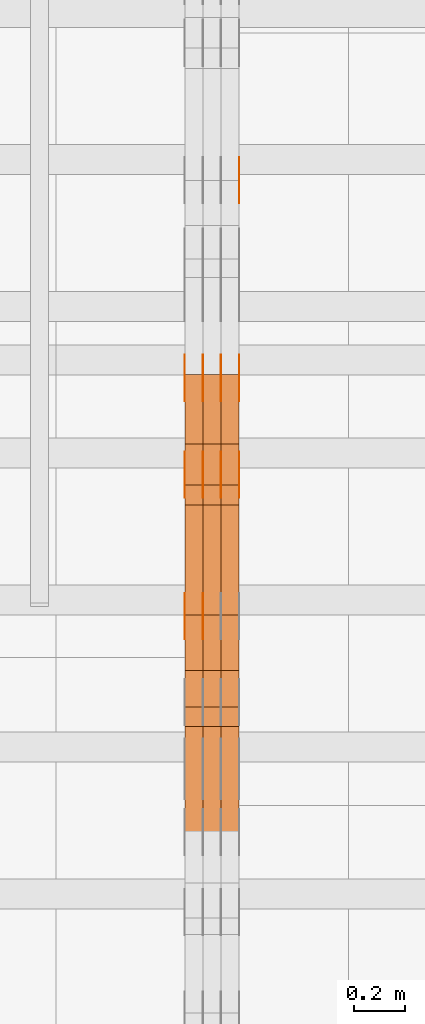
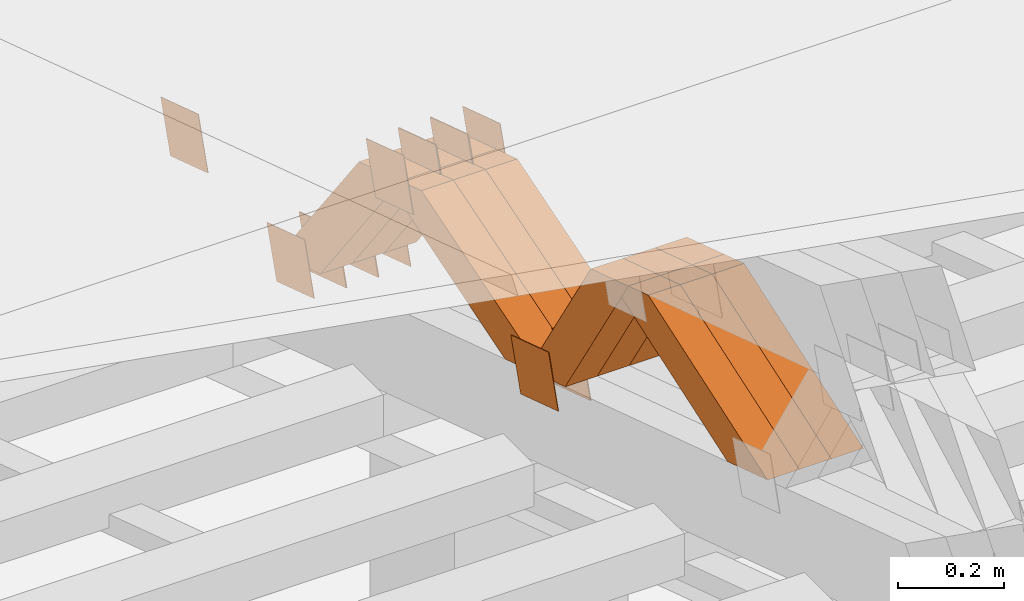
# One storey, part 179 of 385: 28 proxies.
"""IFC2X3 building model written with IfcOpenShell, lengths in millimetres."""

from ifc_helpers import new_model, entity, si_unit, converted_unit, derived_unit, direction, frame, origin, place, context, subcontext, project, spatial, polyline, outline, extrude, source, transform, mapped, material, type_object, type_shapes, element, save


model = new_model("IFC2X3")

# Units and contexts
model_context = context("Model", 3, precision=0.01, world=origin(), true_north=direction((6.12303176911189e-17, 1.0)))
body_context = subcontext(model_context, "Body", "Model", "MODEL_VIEW")
ifc_project = project(units=[si_unit("LENGTHUNIT", "METRE", prefix="MILLI"), si_unit("AREAUNIT", "SQUARE_METRE"), si_unit("VOLUMEUNIT", "CUBIC_METRE"), converted_unit("PLANEANGLEUNIT", "DEGREE", entity("IfcRatioMeasure", 0.0174532925199433), si_unit("PLANEANGLEUNIT", "RADIAN"), dimensions=[0, 0, 0, 0, 0, 0, 0]), si_unit("MASSUNIT", "GRAM", prefix="KILO"), derived_unit("MASSDENSITYUNIT", [(si_unit("MASSUNIT", "GRAM", prefix="KILO"), 1), (si_unit("LENGTHUNIT", "METRE"), -3)]), si_unit("TIMEUNIT", "SECOND"), si_unit("FREQUENCYUNIT", "HERTZ"), si_unit("THERMODYNAMICTEMPERATUREUNIT", "DEGREE_CELSIUS"), derived_unit("THERMALTRANSMITTANCEUNIT", [(si_unit("MASSUNIT", "GRAM", prefix="KILO"), 1), (si_unit("THERMODYNAMICTEMPERATUREUNIT", "KELVIN"), -1), (si_unit("TIMEUNIT", "SECOND"), -3)]), derived_unit("VOLUMETRICFLOWRATEUNIT", [(si_unit("LENGTHUNIT", "METRE"), 3), (si_unit("TIMEUNIT", "SECOND"), -1)]), si_unit("ELECTRICCURRENTUNIT", "AMPERE"), si_unit("ELECTRICVOLTAGEUNIT", "VOLT"), si_unit("POWERUNIT", "WATT"), si_unit("FORCEUNIT", "NEWTON", prefix="KILO"), si_unit("ILLUMINANCEUNIT", "LUX"), si_unit("LUMINOUSFLUXUNIT", "LUMEN"), si_unit("LUMINOUSINTENSITYUNIT", "CANDELA"), derived_unit("USERDEFINED", [(si_unit("MASSUNIT", "GRAM", prefix="KILO"), -1), (si_unit("LENGTHUNIT", "METRE"), -2), (si_unit("TIMEUNIT", "SECOND"), 3), (si_unit("LUMINOUSFLUXUNIT", "LUMEN"), 1)]), derived_unit("LINEARVELOCITYUNIT", [(si_unit("LENGTHUNIT", "METRE"), 1), (si_unit("TIMEUNIT", "SECOND"), -1)]), si_unit("PRESSUREUNIT", "PASCAL"), derived_unit("USERDEFINED", [(si_unit("LENGTHUNIT", "METRE"), -2), (si_unit("MASSUNIT", "GRAM", prefix="KILO"), 1), (si_unit("TIMEUNIT", "SECOND"), -2)])], contexts=[model_context])

# Site, building, storey
site_placement = place(None, origin())
site = spatial("IfcSite", under=ifc_project, at=site_placement, CompositionType="ELEMENT")
building_placement = place(site_placement, origin())
building = spatial("IfcBuilding", under=site, at=building_placement, CompositionType="ELEMENT")
storey_placement = place(building_placement, origin())
storey = spatial("IfcBuildingStorey", under=building, at=storey_placement, Name="Default", CompositionType="ELEMENT", Elevation=0.0)

# Proxies
ifc_material_1 = material(Name="IfcSurfaceStyle #103108")
building_element_proxy_type_1 = type_object("IfcBuildingElementProxyType", PredefinedType="NOTDEFINED", material=ifc_material_1)
shared_shape_1 = source(origin(), body_context, "Body", "SweptSolid", [
    extrude(outline(polyline([(-74.9998794200123, -59.999984515643), (74.9998565677174, -59.999984515643), (74.9998794200123, 59.999984515643), (-74.9998565677174, 59.999984515643), (-74.9998794200123, -59.999984515643)])), frame((75.0000769557496, 60.0000596852268, 0.0), z_axis=(0.0, 0.0, 1.0), x_axis=(-1.0, 0.0, 0.0)), (0.0, 0.0, 1.0), 1.3),
])
type_shapes(building_element_proxy_type_1, [shared_shape_1])
proxy_1_placement = place(building_placement, frame((6386.29999999999, 22649.3668870864, 1282.62115477841), z_axis=(-1.0, 0.0, 0.0), x_axis=(0.0, -0.951056516295124, 0.309016994375039)))
element("IfcBuildingElementProxy", 1, at=proxy_1_placement, inside=storey, type_object=building_element_proxy_type_1, material=ifc_material_1, context=body_context, shape_type="MappedRepresentation", body=[
    mapped(shared_shape_1, transform((0.0, 0.0, 0.0), scale=1.0)),
])
ifc_material_2 = material(Name="IfcSurfaceStyle #100201")
building_element_proxy_type_2 = type_object("IfcBuildingElementProxyType", PredefinedType="NOTDEFINED", material=ifc_material_2)
shared_shape_2 = source(origin(), body_context, "Body", "SweptSolid", [
    extrude(outline(polyline([(-74.9998794200132, -59.999984515643), (74.9998565677174, -59.999984515643), (74.9998794200123, 59.999984515643), (-74.9998565677165, 59.999984515643), (-74.9998794200132, -59.999984515643)])), frame((75.0002235343086, 60.0000596852268, 0.0), z_axis=(0.0, 0.0, 1.0), x_axis=(-1.0, 0.0, 0.0)), (0.0, 0.0, 1.0), 1.29999999999999),
])
type_shapes(building_element_proxy_type_2, [shared_shape_2])
proxy_2_placement = place(building_placement, frame((6245.0, 20956.2317725846, 1832.75404405346), z_axis=(-1.0, 0.0, 0.0), x_axis=(0.0, -0.951056516295124, 0.309016994375039)))
element("IfcBuildingElementProxy", 2, at=proxy_2_placement, inside=storey, type_object=building_element_proxy_type_2, material=ifc_material_2, context=body_context, shape_type="MappedRepresentation", body=[
    mapped(shared_shape_2, transform((0.0, 0.0, 0.0), scale=1.0)),
])
ifc_material_3 = material(Name="IfcSurfaceStyle #100144")
building_element_proxy_type_3 = type_object("IfcBuildingElementProxyType", PredefinedType="NOTDEFINED", material=ifc_material_3)
shared_shape_3 = source(origin(), body_context, "Body", "SweptSolid", [
    extrude(outline(polyline([(-74.9998794200132, -59.999984515643), (74.9998565677174, -59.999984515643), (74.9998794200123, 59.999984515643), (-74.9998565677165, 59.999984515643), (-74.9998794200132, -59.999984515643)])), frame((75.0002235343086, 60.0000596852268, 0.0), z_axis=(0.0, 0.0, 1.0), x_axis=(-1.0, 0.0, 0.0)), (0.0, 0.0, 1.0), 1.29999999999999),
])
type_shapes(building_element_proxy_type_3, [shared_shape_3])
proxy_3_placement = place(building_placement, frame((6246.29999999999, 20956.2317725846, 1832.75404405346), z_axis=(-1.0, 0.0, 0.0), x_axis=(0.0, -0.951056516295124, 0.309016994375039)))
element("IfcBuildingElementProxy", 3, at=proxy_3_placement, inside=storey, type_object=building_element_proxy_type_3, material=ifc_material_3, context=body_context, shape_type="MappedRepresentation", body=[
    mapped(shared_shape_3, transform((0.0, 0.0, 0.0), scale=1.0)),
])
ifc_material_4 = material(Name="IfcSurfaceStyle #100087")
building_element_proxy_type_4 = type_object("IfcBuildingElementProxyType", PredefinedType="NOTDEFINED", material=ifc_material_4)
shared_shape_4 = source(origin(), body_context, "Body", "SweptSolid", [
    extrude(outline(polyline([(-74.9998794200132, -59.999984515643), (74.9998565677174, -59.999984515643), (74.9998794200123, 59.999984515643), (-74.9998565677165, 59.999984515643), (-74.9998794200132, -59.999984515643)])), frame((75.0002235343086, 60.0000596852268, 0.0), z_axis=(0.0, 0.0, 1.0), x_axis=(-1.0, 0.0, 0.0)), (0.0, 0.0, 1.0), 1.29999999999999),
])
type_shapes(building_element_proxy_type_4, [shared_shape_4])
proxy_4_placement = place(building_placement, frame((6175.0, 20956.2317725846, 1832.75404405346), z_axis=(-1.0, 0.0, 0.0), x_axis=(0.0, -0.951056516295124, 0.309016994375039)))
element("IfcBuildingElementProxy", 4, at=proxy_4_placement, inside=storey, type_object=building_element_proxy_type_4, material=ifc_material_4, context=body_context, shape_type="MappedRepresentation", body=[
    mapped(shared_shape_4, transform((0.0, 0.0, 0.0), scale=1.0)),
])
ifc_material_5 = material(Name="IfcSurfaceStyle #100030")
building_element_proxy_type_5 = type_object("IfcBuildingElementProxyType", PredefinedType="NOTDEFINED", material=ifc_material_5)
shared_shape_5 = source(origin(), body_context, "Body", "SweptSolid", [
    extrude(outline(polyline([(-75.0001116115454, -60.0000599592451), (75.0000887592496, -60.0000599592451), (75.0001116115454, 60.0000599592451), (-75.0000887592496, 60.0000599592451), (-75.0001116115454, -60.0000599592451)])), frame((75.0001116115454, 60.0000599592451, 0.0), z_axis=(0.0, 0.0, 1.0), x_axis=(-1.0, 0.0, 0.0)), (0.0, 0.0, 1.0), 1.3),
])
type_shapes(building_element_proxy_type_5, [shared_shape_5])
proxy_5_placement = place(building_placement, frame((6386.29999999999, 21881.0815195707, 1532.2522473242), z_axis=(-1.0, 0.0, 0.0), x_axis=(0.0, -0.951056516295124, 0.309016994375039)))
element("IfcBuildingElementProxy", 5, at=proxy_5_placement, inside=storey, type_object=building_element_proxy_type_5, material=ifc_material_5, context=body_context, shape_type="MappedRepresentation", body=[
    mapped(shared_shape_5, transform((0.0, 0.0, 0.0), scale=1.0)),
])
ifc_material_6 = material(Name="IfcSurfaceStyle #99973")
building_element_proxy_type_6 = type_object("IfcBuildingElementProxyType", PredefinedType="NOTDEFINED", material=ifc_material_6)
shared_shape_6 = source(origin(), body_context, "Body", "SweptSolid", [
    extrude(outline(polyline([(-75.0001116115454, -60.0000599592451), (75.0000887592496, -60.0000599592451), (75.0001116115454, 60.0000599592451), (-75.0000887592496, 60.0000599592451), (-75.0001116115454, -60.0000599592451)])), frame((75.0001116115454, 60.0000599592451, 0.0), z_axis=(0.0, 0.0, 1.0), x_axis=(-1.0, 0.0, 0.0)), (0.0, 0.0, 1.0), 1.3),
])
type_shapes(building_element_proxy_type_6, [shared_shape_6])
proxy_6_placement = place(building_placement, frame((6315.0, 21881.0815195707, 1532.2522473242), z_axis=(-1.0, 0.0, 0.0), x_axis=(0.0, -0.951056516295124, 0.309016994375039)))
element("IfcBuildingElementProxy", 6, at=proxy_6_placement, inside=storey, type_object=building_element_proxy_type_6, material=ifc_material_6, context=body_context, shape_type="MappedRepresentation", body=[
    mapped(shared_shape_6, transform((0.0, 0.0, 0.0), scale=1.0)),
])
ifc_material_7 = material(Name="IfcSurfaceStyle #99916")
building_element_proxy_type_7 = type_object("IfcBuildingElementProxyType", PredefinedType="NOTDEFINED", material=ifc_material_7)
shared_shape_7 = source(origin(), body_context, "Body", "SweptSolid", [
    extrude(outline(polyline([(-75.0001116115454, -60.0000599592451), (75.0000887592496, -60.0000599592451), (75.0001116115454, 60.0000599592451), (-75.0000887592496, 60.0000599592451), (-75.0001116115454, -60.0000599592451)])), frame((75.0001116115454, 60.0000599592451, 0.0), z_axis=(0.0, 0.0, 1.0), x_axis=(-1.0, 0.0, 0.0)), (0.0, 0.0, 1.0), 1.3),
])
type_shapes(building_element_proxy_type_7, [shared_shape_7])
proxy_7_placement = place(building_placement, frame((6316.29999999999, 21881.0815195707, 1532.2522473242), z_axis=(-1.0, 0.0, 0.0), x_axis=(0.0, -0.951056516295124, 0.309016994375039)))
element("IfcBuildingElementProxy", 7, at=proxy_7_placement, inside=storey, type_object=building_element_proxy_type_7, material=ifc_material_7, context=body_context, shape_type="MappedRepresentation", body=[
    mapped(shared_shape_7, transform((0.0, 0.0, 0.0), scale=1.0)),
])
ifc_material_8 = material(Name="IfcSurfaceStyle #99859")
building_element_proxy_type_8 = type_object("IfcBuildingElementProxyType", PredefinedType="NOTDEFINED", material=ifc_material_8)
shared_shape_8 = source(origin(), body_context, "Body", "SweptSolid", [
    extrude(outline(polyline([(-75.0001116115454, -60.0000599592451), (75.0000887592496, -60.0000599592451), (75.0001116115454, 60.0000599592451), (-75.0000887592496, 60.0000599592451), (-75.0001116115454, -60.0000599592451)])), frame((75.0001116115454, 60.0000599592451, 0.0), z_axis=(0.0, 0.0, 1.0), x_axis=(-1.0, 0.0, 0.0)), (0.0, 0.0, 1.0), 1.29999999999999),
])
type_shapes(building_element_proxy_type_8, [shared_shape_8])
proxy_8_placement = place(building_placement, frame((6245.0, 21881.0815195707, 1532.2522473242), z_axis=(-1.0, 0.0, 0.0), x_axis=(0.0, -0.951056516295124, 0.309016994375039)))
element("IfcBuildingElementProxy", 8, at=proxy_8_placement, inside=storey, type_object=building_element_proxy_type_8, material=ifc_material_8, context=body_context, shape_type="MappedRepresentation", body=[
    mapped(shared_shape_8, transform((0.0, 0.0, 0.0), scale=1.0)),
])
ifc_material_9 = material(Name="IfcSurfaceStyle #99802")
building_element_proxy_type_9 = type_object("IfcBuildingElementProxyType", PredefinedType="NOTDEFINED", material=ifc_material_9)
shared_shape_9 = source(origin(), body_context, "Body", "SweptSolid", [
    extrude(outline(polyline([(-75.0001116115454, -60.0000599592451), (75.0000887592496, -60.0000599592451), (75.0001116115454, 60.0000599592451), (-75.0000887592496, 60.0000599592451), (-75.0001116115454, -60.0000599592451)])), frame((75.0001116115454, 60.0000599592451, 0.0), z_axis=(0.0, 0.0, 1.0), x_axis=(-1.0, 0.0, 0.0)), (0.0, 0.0, 1.0), 1.29999999999999),
])
type_shapes(building_element_proxy_type_9, [shared_shape_9])
proxy_9_placement = place(building_placement, frame((6246.29999999999, 21881.0815195707, 1532.2522473242), z_axis=(-1.0, 0.0, 0.0), x_axis=(0.0, -0.951056516295124, 0.309016994375039)))
element("IfcBuildingElementProxy", 9, at=proxy_9_placement, inside=storey, type_object=building_element_proxy_type_9, material=ifc_material_9, context=body_context, shape_type="MappedRepresentation", body=[
    mapped(shared_shape_9, transform((0.0, 0.0, 0.0), scale=1.0)),
])
ifc_material_10 = material(Name="IfcSurfaceStyle #99745")
building_element_proxy_type_10 = type_object("IfcBuildingElementProxyType", PredefinedType="NOTDEFINED", material=ifc_material_10)
shared_shape_10 = source(origin(), body_context, "Body", "SweptSolid", [
    extrude(outline(polyline([(-75.0001116115454, -60.0000599592451), (75.0000887592496, -60.0000599592451), (75.0001116115454, 60.0000599592451), (-75.0000887592496, 60.0000599592451), (-75.0001116115454, -60.0000599592451)])), frame((75.0001116115454, 60.0000599592451, 0.0), z_axis=(0.0, 0.0, 1.0), x_axis=(-1.0, 0.0, 0.0)), (0.0, 0.0, 1.0), 1.29999999999999),
])
type_shapes(building_element_proxy_type_10, [shared_shape_10])
proxy_10_placement = place(building_placement, frame((6175.0, 21881.0815195707, 1532.2522473242), z_axis=(-1.0, 0.0, 0.0), x_axis=(0.0, -0.951056516295124, 0.309016994375039)))
element("IfcBuildingElementProxy", 10, at=proxy_10_placement, inside=storey, type_object=building_element_proxy_type_10, material=ifc_material_10, context=body_context, shape_type="MappedRepresentation", body=[
    mapped(shared_shape_10, transform((0.0, 0.0, 0.0), scale=1.0)),
])
ifc_material_11 = material(Name="IfcSurfaceStyle #94558")
building_element_proxy_type_11 = type_object("IfcBuildingElementProxyType", PredefinedType="NOTDEFINED", material=ifc_material_11)
shared_shape_11 = source(origin(), body_context, "Body", "SweptSolid", [
    extrude(outline(polyline([(-74.9998794200064, -59.9999845156358), (74.9998565677224, -59.9999845156358), (74.9998794200064, 59.9999845156358), (-74.9998565677224, 59.9999845156358), (-74.9998794200064, -59.9999845156358)])), frame((74.9999765995044, 60.0000596852337, 0.0), z_axis=(0.0, 0.0, 1.0), x_axis=(-1.0, 0.0, 0.0)), (0.0, 0.0, 1.0), 1.3),
])
type_shapes(building_element_proxy_type_11, [shared_shape_11])
proxy_11_placement = place(building_placement, frame((6386.29999999999, 21505.9776314857, 1954.5332951652), z_axis=(-1.0, 0.0, 0.0), x_axis=(0.0, -0.951056516295154, 0.309016994374948)))
element("IfcBuildingElementProxy", 11, at=proxy_11_placement, inside=storey, type_object=building_element_proxy_type_11, material=ifc_material_11, context=body_context, shape_type="MappedRepresentation", body=[
    mapped(shared_shape_11, transform((0.0, 0.0, 0.0), scale=1.0)),
])
ifc_material_12 = material(Name="IfcSurfaceStyle #94501")
building_element_proxy_type_12 = type_object("IfcBuildingElementProxyType", PredefinedType="NOTDEFINED", material=ifc_material_12)
shared_shape_12 = source(origin(), body_context, "Body", "SweptSolid", [
    extrude(outline(polyline([(-74.9998794200064, -59.9999845156358), (74.9998565677224, -59.9999845156358), (74.9998794200064, 59.9999845156358), (-74.9998565677224, 59.9999845156358), (-74.9998794200064, -59.9999845156358)])), frame((74.9999765995044, 60.0000596852337, 0.0), z_axis=(0.0, 0.0, 1.0), x_axis=(-1.0, 0.0, 0.0)), (0.0, 0.0, 1.0), 1.3),
])
type_shapes(building_element_proxy_type_12, [shared_shape_12])
proxy_12_placement = place(building_placement, frame((6315.0, 21505.9776314857, 1954.5332951652), z_axis=(-1.0, 0.0, 0.0), x_axis=(0.0, -0.951056516295154, 0.309016994374948)))
element("IfcBuildingElementProxy", 12, at=proxy_12_placement, inside=storey, type_object=building_element_proxy_type_12, material=ifc_material_12, context=body_context, shape_type="MappedRepresentation", body=[
    mapped(shared_shape_12, transform((0.0, 0.0, 0.0), scale=1.0)),
])
ifc_material_13 = material(Name="IfcSurfaceStyle #94444")
building_element_proxy_type_13 = type_object("IfcBuildingElementProxyType", PredefinedType="NOTDEFINED", material=ifc_material_13)
shared_shape_13 = source(origin(), body_context, "Body", "SweptSolid", [
    extrude(outline(polyline([(-74.9998794200064, -59.9999845156358), (74.9998565677224, -59.9999845156358), (74.9998794200064, 59.9999845156358), (-74.9998565677224, 59.9999845156358), (-74.9998794200064, -59.9999845156358)])), frame((74.9999765995044, 60.0000596852337, 0.0), z_axis=(0.0, 0.0, 1.0), x_axis=(-1.0, 0.0, 0.0)), (0.0, 0.0, 1.0), 1.3),
])
type_shapes(building_element_proxy_type_13, [shared_shape_13])
proxy_13_placement = place(building_placement, frame((6316.29999999999, 21505.9776314857, 1954.5332951652), z_axis=(-1.0, 0.0, 0.0), x_axis=(0.0, -0.951056516295154, 0.309016994374948)))
element("IfcBuildingElementProxy", 13, at=proxy_13_placement, inside=storey, type_object=building_element_proxy_type_13, material=ifc_material_13, context=body_context, shape_type="MappedRepresentation", body=[
    mapped(shared_shape_13, transform((0.0, 0.0, 0.0), scale=1.0)),
])
ifc_material_14 = material(Name="IfcSurfaceStyle #94387")
building_element_proxy_type_14 = type_object("IfcBuildingElementProxyType", PredefinedType="NOTDEFINED", material=ifc_material_14)
shared_shape_14 = source(origin(), body_context, "Body", "SweptSolid", [
    extrude(outline(polyline([(-74.9998794200064, -59.9999845156358), (74.9998565677224, -59.9999845156358), (74.9998794200064, 59.9999845156358), (-74.9998565677224, 59.9999845156358), (-74.9998794200064, -59.9999845156358)])), frame((74.9999765995044, 60.0000596852337, 0.0), z_axis=(0.0, 0.0, 1.0), x_axis=(-1.0, 0.0, 0.0)), (0.0, 0.0, 1.0), 1.29999999999999),
])
type_shapes(building_element_proxy_type_14, [shared_shape_14])
proxy_14_placement = place(building_placement, frame((6245.0, 21505.9776314857, 1954.5332951652), z_axis=(-1.0, 0.0, 0.0), x_axis=(0.0, -0.951056516295154, 0.309016994374948)))
element("IfcBuildingElementProxy", 14, at=proxy_14_placement, inside=storey, type_object=building_element_proxy_type_14, material=ifc_material_14, context=body_context, shape_type="MappedRepresentation", body=[
    mapped(shared_shape_14, transform((0.0, 0.0, 0.0), scale=1.0)),
])
ifc_material_15 = material(Name="IfcSurfaceStyle #94330")
building_element_proxy_type_15 = type_object("IfcBuildingElementProxyType", PredefinedType="NOTDEFINED", material=ifc_material_15)
shared_shape_15 = source(origin(), body_context, "Body", "SweptSolid", [
    extrude(outline(polyline([(-74.9998794200064, -59.9999845156358), (74.9998565677224, -59.9999845156358), (74.9998794200064, 59.9999845156358), (-74.9998565677224, 59.9999845156358), (-74.9998794200064, -59.9999845156358)])), frame((74.9999765995044, 60.0000596852337, 0.0), z_axis=(0.0, 0.0, 1.0), x_axis=(-1.0, 0.0, 0.0)), (0.0, 0.0, 1.0), 1.29999999999999),
])
type_shapes(building_element_proxy_type_15, [shared_shape_15])
proxy_15_placement = place(building_placement, frame((6246.29999999999, 21505.9776314857, 1954.5332951652), z_axis=(-1.0, 0.0, 0.0), x_axis=(0.0, -0.951056516295154, 0.309016994374948)))
element("IfcBuildingElementProxy", 15, at=proxy_15_placement, inside=storey, type_object=building_element_proxy_type_15, material=ifc_material_15, context=body_context, shape_type="MappedRepresentation", body=[
    mapped(shared_shape_15, transform((0.0, 0.0, 0.0), scale=1.0)),
])
ifc_material_16 = material(Name="IfcSurfaceStyle #94273")
building_element_proxy_type_16 = type_object("IfcBuildingElementProxyType", PredefinedType="NOTDEFINED", material=ifc_material_16)
shared_shape_16 = source(origin(), body_context, "Body", "SweptSolid", [
    extrude(outline(polyline([(-74.9998794200064, -59.9999845156358), (74.9998565677224, -59.9999845156358), (74.9998794200064, 59.9999845156358), (-74.9998565677224, 59.9999845156358), (-74.9998794200064, -59.9999845156358)])), frame((74.9999765995044, 60.0000596852337, 0.0), z_axis=(0.0, 0.0, 1.0), x_axis=(-1.0, 0.0, 0.0)), (0.0, 0.0, 1.0), 1.29999999999999),
])
type_shapes(building_element_proxy_type_16, [shared_shape_16])
proxy_16_placement = place(building_placement, frame((6175.0, 21505.9776314857, 1954.5332951652), z_axis=(-1.0, 0.0, 0.0), x_axis=(0.0, -0.951056516295154, 0.309016994374948)))
element("IfcBuildingElementProxy", 16, at=proxy_16_placement, inside=storey, type_object=building_element_proxy_type_16, material=ifc_material_16, context=body_context, shape_type="MappedRepresentation", body=[
    mapped(shared_shape_16, transform((0.0, 0.0, 0.0), scale=1.0)),
])
ifc_material_17 = material(Name="IfcSurfaceStyle #83110")
building_element_proxy_type_17 = type_object("IfcBuildingElementProxyType", Name="T1-W26 83108", PredefinedType="NOTDEFINED", material=ifc_material_17)
shared_shape_17 = source(origin(), body_context, "Body", "SweptSolid", [
    extrude(outline(polyline([(-339.390941716546, -47.5001331548025), (137.738864791781, -47.5001331548025), (201.272298560955, 6.02772073885038e-05), (212.703852542003, 47.5001030161988), (-212.324074178193, 47.5001030161988), (-339.390941716546, -47.5001331548025)])), frame((212.703852542003, 47.5001030161988, 0.0), z_axis=(0.0, 0.0, 1.0), x_axis=(-1.0, 0.0, 0.0)), (0.0, 0.0, 1.0), 70.0),
])
type_shapes(building_element_proxy_type_17, [shared_shape_17])
proxy_17_placement = place(building_placement, frame((6385.0, 20576.541015625, 2286.80981445313), z_axis=(-1.0, 0.0, 0.0), x_axis=(0.0, -0.946743816465327, -0.321987804093053)))
element("IfcBuildingElementProxy", 17, at=proxy_17_placement, inside=storey, type_object=building_element_proxy_type_17, material=ifc_material_17, Name="T1-W26", context=body_context, shape_type="MappedRepresentation", body=[
    mapped(shared_shape_17, transform((0.0, 0.0, 0.0), scale=1.0)),
])
ifc_material_18 = material(Name="IfcSurfaceStyle #83044")
building_element_proxy_type_18 = type_object("IfcBuildingElementProxyType", Name="T1-W26 83042", PredefinedType="NOTDEFINED", material=ifc_material_18)
shared_shape_18 = source(origin(), body_context, "Body", "SweptSolid", [
    extrude(outline(polyline([(-339.390941716546, -47.5001331548025), (137.738864791781, -47.5001331548025), (201.272298560955, 6.02772073885038e-05), (212.703852542003, 47.5001030161988), (-212.324074178193, 47.5001030161988), (-339.390941716546, -47.5001331548025)])), frame((212.703852542003, 47.5001030161988, 0.0), z_axis=(0.0, 0.0, 1.0), x_axis=(-1.0, 0.0, 0.0)), (0.0, 0.0, 1.0), 70.0),
])
type_shapes(building_element_proxy_type_18, [shared_shape_18])
proxy_18_placement = place(building_placement, frame((6315.0, 20576.541015625, 2286.80981445313), z_axis=(-1.0, 0.0, 0.0), x_axis=(0.0, -0.946743816465327, -0.321987804093053)))
element("IfcBuildingElementProxy", 18, at=proxy_18_placement, inside=storey, type_object=building_element_proxy_type_18, material=ifc_material_18, Name="T1-W26", context=body_context, shape_type="MappedRepresentation", body=[
    mapped(shared_shape_18, transform((0.0, 0.0, 0.0), scale=1.0)),
])
ifc_material_19 = material(Name="IfcSurfaceStyle #82978")
building_element_proxy_type_19 = type_object("IfcBuildingElementProxyType", Name="T1-W26 82976", PredefinedType="NOTDEFINED", material=ifc_material_19)
shared_shape_19 = source(origin(), body_context, "Body", "SweptSolid", [
    extrude(outline(polyline([(-339.390941716546, -47.5001331548025), (137.738864791781, -47.5001331548025), (201.272298560955, 6.02772073885038e-05), (212.703852542003, 47.5001030161988), (-212.324074178193, 47.5001030161988), (-339.390941716546, -47.5001331548025)])), frame((212.703852542003, 47.5001030161988, 0.0), z_axis=(0.0, 0.0, 1.0), x_axis=(-1.0, 0.0, 0.0)), (0.0, 0.0, 1.0), 70.0),
])
type_shapes(building_element_proxy_type_19, [shared_shape_19])
proxy_19_placement = place(building_placement, frame((6245.0, 20576.541015625, 2286.80981445313), z_axis=(-1.0, 0.0, 0.0), x_axis=(0.0, -0.946743816465327, -0.321987804093053)))
element("IfcBuildingElementProxy", 19, at=proxy_19_placement, inside=storey, type_object=building_element_proxy_type_19, material=ifc_material_19, Name="T1-W26", context=body_context, shape_type="MappedRepresentation", body=[
    mapped(shared_shape_19, transform((0.0, 0.0, 0.0), scale=1.0)),
])
ifc_material_20 = material(Name="IfcSurfaceStyle #82714")
building_element_proxy_type_20 = type_object("IfcBuildingElementProxyType", Name="T1-W29 82712", PredefinedType="NOTDEFINED", material=ifc_material_20)
shared_shape_20 = source(origin(), body_context, "Body", "SweptSolid", [
    extrude(outline(polyline([(-202.325994317059, -47.5000867467013), (200.714255560873, -47.5000867467013), (187.834128885383, 0.000593513395139059), (130.590899902046, 47.4997899900038), (-316.813290031243, 47.4997899900038), (-202.325994317059, -47.5000867467013)])), frame((200.714255560873, 47.5001935424745, 0.0), z_axis=(0.0, 0.0, 1.0), x_axis=(-1.0, 0.0, 0.0)), (0.0, 0.0, 1.0), 70.0),
])
type_shapes(building_element_proxy_type_20, [shared_shape_20])
proxy_20_placement = place(building_placement, frame((6385.0, 20827.0771193222, 1890.72342063252), z_axis=(-1.0, 0.0, 0.0), x_axis=(0.0, -0.534567451138397, 0.845125813227473)))
element("IfcBuildingElementProxy", 20, at=proxy_20_placement, inside=storey, type_object=building_element_proxy_type_20, material=ifc_material_20, Name="T1-W29", context=body_context, shape_type="MappedRepresentation", body=[
    mapped(shared_shape_20, transform((0.0, 0.0, 0.0), scale=1.0)),
])
ifc_material_21 = material(Name="IfcSurfaceStyle #82648")
building_element_proxy_type_21 = type_object("IfcBuildingElementProxyType", Name="T1-W29 82646", PredefinedType="NOTDEFINED", material=ifc_material_21)
shared_shape_21 = source(origin(), body_context, "Body", "SweptSolid", [
    extrude(outline(polyline([(-202.325994317059, -47.5000867467013), (200.714255560873, -47.5000867467013), (187.834128885383, 0.000593513395139059), (130.590899902046, 47.4997899900038), (-316.813290031243, 47.4997899900038), (-202.325994317059, -47.5000867467013)])), frame((200.714255560873, 47.5001935424745, 0.0), z_axis=(0.0, 0.0, 1.0), x_axis=(-1.0, 0.0, 0.0)), (0.0, 0.0, 1.0), 70.0),
])
type_shapes(building_element_proxy_type_21, [shared_shape_21])
proxy_21_placement = place(building_placement, frame((6315.0, 20827.0771193222, 1890.72342063252), z_axis=(-1.0, 0.0, 0.0), x_axis=(0.0, -0.534567451138397, 0.845125813227473)))
element("IfcBuildingElementProxy", 21, at=proxy_21_placement, inside=storey, type_object=building_element_proxy_type_21, material=ifc_material_21, Name="T1-W29", context=body_context, shape_type="MappedRepresentation", body=[
    mapped(shared_shape_21, transform((0.0, 0.0, 0.0), scale=1.0)),
])
ifc_material_22 = material(Name="IfcSurfaceStyle #82582")
building_element_proxy_type_22 = type_object("IfcBuildingElementProxyType", Name="T1-W29 82580", PredefinedType="NOTDEFINED", material=ifc_material_22)
shared_shape_22 = source(origin(), body_context, "Body", "SweptSolid", [
    extrude(outline(polyline([(-202.325994317059, -47.5000867467013), (200.714255560873, -47.5000867467013), (187.834128885383, 0.000593513395139059), (130.590899902046, 47.4997899900038), (-316.813290031243, 47.4997899900038), (-202.325994317059, -47.5000867467013)])), frame((200.714255560873, 47.5001935424745, 0.0), z_axis=(0.0, 0.0, 1.0), x_axis=(-1.0, 0.0, 0.0)), (0.0, 0.0, 1.0), 70.0),
])
type_shapes(building_element_proxy_type_22, [shared_shape_22])
proxy_22_placement = place(building_placement, frame((6245.0, 20827.0771193222, 1890.72342063252), z_axis=(-1.0, 0.0, 0.0), x_axis=(0.0, -0.534567451138397, 0.845125813227473)))
element("IfcBuildingElementProxy", 22, at=proxy_22_placement, inside=storey, type_object=building_element_proxy_type_22, material=ifc_material_22, Name="T1-W29", context=body_context, shape_type="MappedRepresentation", body=[
    mapped(shared_shape_22, transform((0.0, 0.0, 0.0), scale=1.0)),
])
ifc_material_23 = material(Name="IfcSurfaceStyle #82318")
building_element_proxy_type_23 = type_object("IfcBuildingElementProxyType", Name="T1-W20 82316", PredefinedType="NOTDEFINED", material=ifc_material_23)
shared_shape_23 = source(origin(), body_context, "Body", "SweptSolid", [
    extrude(outline(polyline([(-355.264945969921, -47.5000317999193), (141.064821099313, -47.5000317999193), (208.541978467889, 8.19311626391928e-05), (225.96877763549, 47.499990834338), (-220.31063123277, 47.4999908343379), (-355.264945969921, -47.5000317999193)])), frame((225.968921063481, 47.5000683592689, 0.0), z_axis=(0.0, 0.0, 1.0), x_axis=(-1.0, 0.0, 0.0)), (0.0, 0.0, 1.0), 70.0),
])
type_shapes(building_element_proxy_type_23, [shared_shape_23])
proxy_23_placement = place(building_placement, frame((6385.0, 21443.7472302196, 2007.54830804072), z_axis=(-1.0, 0.0, 0.0), x_axis=(0.0, -0.95556995517236, -0.29476441571515)))
element("IfcBuildingElementProxy", 23, at=proxy_23_placement, inside=storey, type_object=building_element_proxy_type_23, material=ifc_material_23, Name="T1-W20", context=body_context, shape_type="MappedRepresentation", body=[
    mapped(shared_shape_23, transform((0.0, 0.0, 0.0), scale=1.0)),
])
ifc_material_24 = material(Name="IfcSurfaceStyle #82252")
building_element_proxy_type_24 = type_object("IfcBuildingElementProxyType", Name="T1-W20 82250", PredefinedType="NOTDEFINED", material=ifc_material_24)
shared_shape_24 = source(origin(), body_context, "Body", "SweptSolid", [
    extrude(outline(polyline([(-355.264945969921, -47.5000317999193), (141.064821099313, -47.5000317999193), (208.541978467889, 8.19311626391928e-05), (225.96877763549, 47.499990834338), (-220.31063123277, 47.4999908343379), (-355.264945969921, -47.5000317999193)])), frame((225.968921063481, 47.5000683592689, 0.0), z_axis=(0.0, 0.0, 1.0), x_axis=(-1.0, 0.0, 0.0)), (0.0, 0.0, 1.0), 70.0),
])
type_shapes(building_element_proxy_type_24, [shared_shape_24])
proxy_24_placement = place(building_placement, frame((6315.0, 21443.7472302196, 2007.54830804072), z_axis=(-1.0, 0.0, 0.0), x_axis=(0.0, -0.95556995517236, -0.29476441571515)))
element("IfcBuildingElementProxy", 24, at=proxy_24_placement, inside=storey, type_object=building_element_proxy_type_24, material=ifc_material_24, Name="T1-W20", context=body_context, shape_type="MappedRepresentation", body=[
    mapped(shared_shape_24, transform((0.0, 0.0, 0.0), scale=1.0)),
])
ifc_material_25 = material(Name="IfcSurfaceStyle #82186")
building_element_proxy_type_25 = type_object("IfcBuildingElementProxyType", Name="T1-W20 82184", PredefinedType="NOTDEFINED", material=ifc_material_25)
shared_shape_25 = source(origin(), body_context, "Body", "SweptSolid", [
    extrude(outline(polyline([(-355.264945969921, -47.5000317999193), (141.064821099313, -47.5000317999193), (208.541978467889, 8.19311626391928e-05), (225.96877763549, 47.499990834338), (-220.31063123277, 47.4999908343379), (-355.264945969921, -47.5000317999193)])), frame((225.968921063481, 47.5000683592689, 0.0), z_axis=(0.0, 0.0, 1.0), x_axis=(-1.0, 0.0, 0.0)), (0.0, 0.0, 1.0), 70.0),
])
type_shapes(building_element_proxy_type_25, [shared_shape_25])
proxy_25_placement = place(building_placement, frame((6245.0, 21443.7472302196, 2007.54830804072), z_axis=(-1.0, 0.0, 0.0), x_axis=(0.0, -0.95556995517236, -0.29476441571515)))
element("IfcBuildingElementProxy", 25, at=proxy_25_placement, inside=storey, type_object=building_element_proxy_type_25, material=ifc_material_25, Name="T1-W20", context=body_context, shape_type="MappedRepresentation", body=[
    mapped(shared_shape_25, transform((0.0, 0.0, 0.0), scale=1.0)),
])
ifc_material_26 = material(Name="IfcSurfaceStyle #81922")
building_element_proxy_type_26 = type_object("IfcBuildingElementProxyType", Name="T1-W18 81920", PredefinedType="NOTDEFINED", material=ifc_material_26)
shared_shape_26 = source(origin(), body_context, "Body", "SweptSolid", [
    extrude(outline(polyline([(-221.504996322134, -47.4999929258616), (225.406467948779, -47.4999929258616), (211.663832468686, -0.000107703153482008), (143.08905281687, 47.5000467774384), (-358.6543569122, 47.5000467774384), (-221.504996322134, -47.4999929258616)])), frame((225.406576158364, 47.5000467774384, 0.0), z_axis=(0.0, 0.0, 1.0), x_axis=(-1.0, 0.0, 0.0)), (0.0, 0.0, 1.0), 70.0),
])
type_shapes(building_element_proxy_type_26, [shared_shape_26])
proxy_26_placement = place(building_placement, frame((6385.0, 21766.9513837803, 1583.13813361817), z_axis=(-1.0, 0.0, 0.0), x_axis=(0.0, -0.605858491298265, 0.795572428206126)))
element("IfcBuildingElementProxy", 26, at=proxy_26_placement, inside=storey, type_object=building_element_proxy_type_26, material=ifc_material_26, Name="T1-W18", context=body_context, shape_type="MappedRepresentation", body=[
    mapped(shared_shape_26, transform((0.0, 0.0, 0.0), scale=1.0)),
])
ifc_material_27 = material(Name="IfcSurfaceStyle #81856")
building_element_proxy_type_27 = type_object("IfcBuildingElementProxyType", Name="T1-W18 81854", PredefinedType="NOTDEFINED", material=ifc_material_27)
shared_shape_27 = source(origin(), body_context, "Body", "SweptSolid", [
    extrude(outline(polyline([(-221.504996322134, -47.4999929258616), (225.406467948779, -47.4999929258616), (211.663832468686, -0.000107703153482008), (143.08905281687, 47.5000467774384), (-358.6543569122, 47.5000467774384), (-221.504996322134, -47.4999929258616)])), frame((225.406576158364, 47.5000467774384, 0.0), z_axis=(0.0, 0.0, 1.0), x_axis=(-1.0, 0.0, 0.0)), (0.0, 0.0, 1.0), 70.0),
])
type_shapes(building_element_proxy_type_27, [shared_shape_27])
proxy_27_placement = place(building_placement, frame((6315.0, 21766.9513837803, 1583.13813361817), z_axis=(-1.0, 0.0, 0.0), x_axis=(0.0, -0.605858491298265, 0.795572428206126)))
element("IfcBuildingElementProxy", 27, at=proxy_27_placement, inside=storey, type_object=building_element_proxy_type_27, material=ifc_material_27, Name="T1-W18", context=body_context, shape_type="MappedRepresentation", body=[
    mapped(shared_shape_27, transform((0.0, 0.0, 0.0), scale=1.0)),
])
ifc_material_28 = material(Name="IfcSurfaceStyle #81790")
building_element_proxy_type_28 = type_object("IfcBuildingElementProxyType", Name="T1-W18 81788", PredefinedType="NOTDEFINED", material=ifc_material_28)
shared_shape_28 = source(origin(), body_context, "Body", "SweptSolid", [
    extrude(outline(polyline([(-221.504996322134, -47.4999929258616), (225.406467948779, -47.4999929258616), (211.663832468686, -0.000107703153482008), (143.08905281687, 47.5000467774384), (-358.6543569122, 47.5000467774384), (-221.504996322134, -47.4999929258616)])), frame((225.406576158364, 47.5000467774384, 0.0), z_axis=(0.0, 0.0, 1.0), x_axis=(-1.0, 0.0, 0.0)), (0.0, 0.0, 1.0), 70.0),
])
type_shapes(building_element_proxy_type_28, [shared_shape_28])
proxy_28_placement = place(building_placement, frame((6245.0, 21766.9513837803, 1583.13813361817), z_axis=(-1.0, 0.0, 0.0), x_axis=(0.0, -0.605858491298265, 0.795572428206126)))
element("IfcBuildingElementProxy", 28, at=proxy_28_placement, inside=storey, type_object=building_element_proxy_type_28, material=ifc_material_28, Name="T1-W18", context=body_context, shape_type="MappedRepresentation", body=[
    mapped(shared_shape_28, transform((0.0, 0.0, 0.0), scale=1.0)),
])

save(model, "model.ifc")
